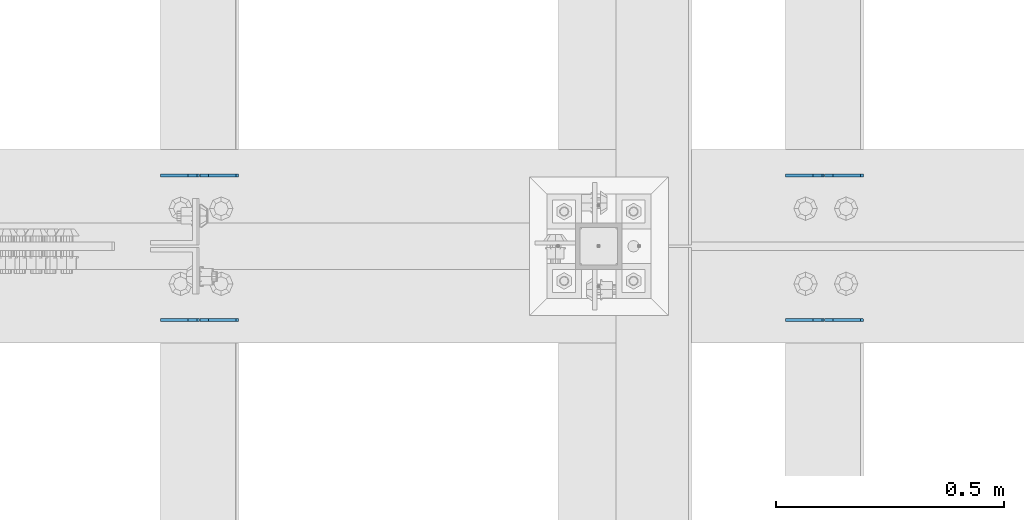
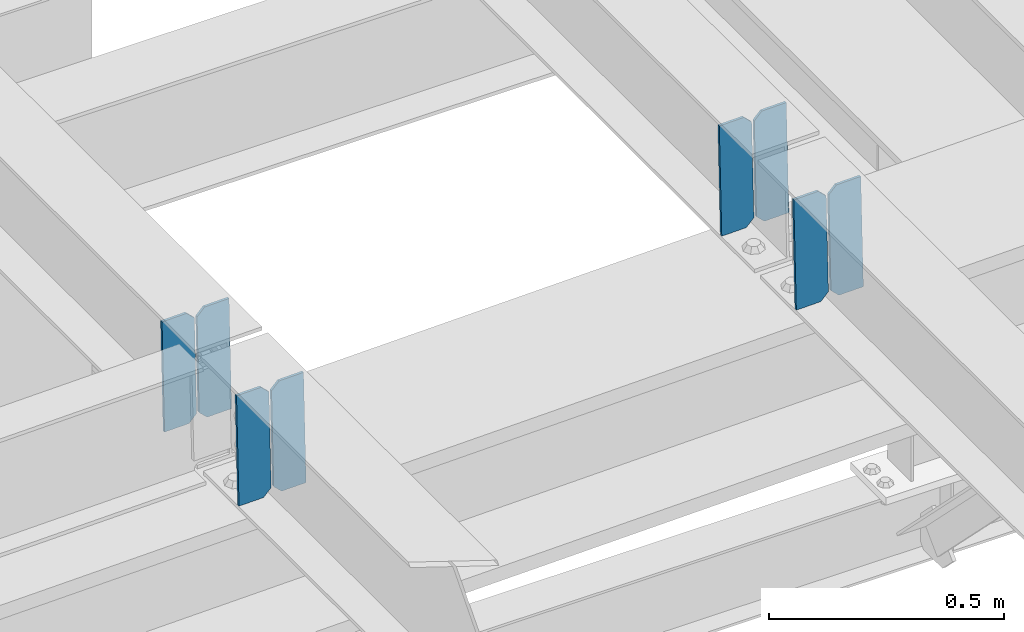
# One storey, part 3397 of 3843: 8 plates, 4 elements without a shape of their own.
"""IFC2X3 building model written with IfcOpenShell, lengths in millimetres."""

from ifc_helpers import new_model, si_unit, frame, origin_with_axes, place, context, subcontext, project, spatial, faceted_brep, material, type_object, element, aggregate, save


model = new_model("IFC2X3")

# Units and contexts
model_context = context("Model", 3, precision=1e-05, world=origin_with_axes())
body_context = subcontext(model_context, "Body", "Model", "MODEL_VIEW")
ifc_project = project(units=[si_unit("LENGTHUNIT", "METRE", prefix="MILLI"), si_unit("AREAUNIT", "SQUARE_METRE"), si_unit("VOLUMEUNIT", "CUBIC_METRE"), si_unit("MASSUNIT", "GRAM", prefix="KILO"), si_unit("TIMEUNIT", "SECOND"), si_unit("PLANEANGLEUNIT", "RADIAN"), si_unit("SOLIDANGLEUNIT", "STERADIAN"), si_unit("THERMODYNAMICTEMPERATUREUNIT", "DEGREE_CELSIUS"), si_unit("LUMINOUSINTENSITYUNIT", "LUMEN")], contexts=[model_context])

# Site, building, storey
site_placement = place(None, origin_with_axes())
site = spatial("IfcSite", under=ifc_project, at=site_placement, CompositionType="ELEMENT")
building_placement = place(site_placement, origin_with_axes())
building = spatial("IfcBuilding", under=site, at=building_placement, Name="Undefined", CompositionType="ELEMENT")
storey_placement = place(building_placement, origin_with_axes())
storey = spatial("IfcBuildingStorey", under=building, at=storey_placement, Name="Undefined", CompositionType="ELEMENT", Elevation=0.0)

# Assembly, plates
assembly_1_placement = place(storey_placement, origin_with_axes())
assembly_1 = element("IfcElementAssembly", 1, at=assembly_1_placement, inside=storey, Name="BEAM", AssemblyPlace="NOTDEFINED", PredefinedType="RIGID_FRAME")
ifc_material = material(Name="STEEL/A572-50")
plate_type = type_object("IfcPlateType", PredefinedType="NOTDEFINED")
plate_1_placement = place(assembly_1_placement, frame((39401.4964783447, 84140.6303417167, 45490.5687966606), z_axis=(-0.0211520982443035, 0.000149702000009711, 0.999776258134376), x_axis=(-0.999776269342228, -3.16699999781408e-06, -0.0211520980072162)))
plate_1 = element("IfcPlate", 2, at=plate_1_placement, type_object=plate_type, material=ifc_material, Name="PLATE", context=body_context, shape_type="Brep", body=[
    faceted_brep([(0.0, -3.17499999999927, 0.0), (6.83940015733242e-10, -3.17499999996653, 288.924999998613), (6.54836185276508e-10, 3.17500000001746, 288.924999998591), (0.0, 3.17499999999927, 0.0), (60.3250007643655, -3.17500000017753, 288.924999998606), (60.3250007643219, 3.17499999979918, 288.924999998584), (79.3750000013097, -3.17500000025029, 269.875000761494), (79.375000001266, 3.17499999972642, 269.875000761487), (79.375000000713, -3.17500000026484, 19.0499992370605), (79.3750000006985, 3.17499999971187, 19.0499992370533), (60.325000763667, -3.17500000020664, -1.45519152283669e-11), (60.3250007636234, 3.17499999977736, -3.63797880709171e-11)], [[[0, 1, 2, 3]], [[1, 4, 5, 2]], [[4, 6, 7, 5]], [[6, 8, 9, 7]], [[8, 10, 11, 9]], [[10, 0, 3, 11]], [[5, 7, 9, 11, 3, 2]], [[10, 8, 6, 4, 1, 0]]]),
])
plate_2_placement = place(assembly_1_placement, frame((39315.7906576554, 84140.6300702067, 45488.75553308), z_axis=(-0.0211520982443035, 0.000149702000009711, 0.999776258134376), x_axis=(-0.999776269342228, -3.16699999781408e-06, -0.0211520980072162)))
plate_2 = element("IfcPlate", 3, at=plate_2_placement, type_object=plate_type, material=ifc_material, Name="PLATE", context=body_context, shape_type="Brep", body=[
    faceted_brep([(4.36557456851006e-11, -3.17499999998836, 19.0499992370969), (6.11180439591408e-10, -3.17499999996653, 269.875000761516), (5.96628524363041e-10, 3.17500000001746, 269.875000761502), (1.45519152283669e-11, 3.17499999998836, 19.0499992370824), (19.0499992376572, -3.17500000003201, 288.924999998606), (19.0499992376281, 3.1749999999447, 288.924999998584), (79.3750000013242, -3.17500000025029, 288.924999998591), (79.3750000013097, 3.1749999997337, 288.92499999857), (79.3750000006548, -3.17500000026484, -2.18278728425503e-11), (79.3750000006403, 3.17499999969732, -2.91038304567337e-11), (19.0499992370023, -3.17500000005384, 0.0), (19.0499992369587, 3.17499999992287, -1.45519152283669e-11)], [[[0, 1, 2, 3]], [[1, 4, 5, 2]], [[4, 6, 7, 5]], [[6, 8, 9, 7]], [[8, 10, 11, 9]], [[10, 0, 3, 11]], [[5, 7, 9, 11, 3, 2]], [[10, 8, 6, 4, 1, 0]]]),
])
aggregate(assembly_1, [plate_1, plate_2])

assembly_2_placement = place(storey_placement, origin_with_axes())
assembly_2 = element("IfcElementAssembly", 4, at=assembly_2_placement, inside=storey, Name="BEAM", AssemblyPlace="NOTDEFINED", PredefinedType="RIGID_FRAME")
plate_3_placement = place(assembly_2_placement, frame((39401.4964782663, 83822.7338308514, 45490.8324863675), z_axis=(-0.0211520981891954, 0.00148016899947834, 0.999775173647519), x_axis=(-0.999776269354785, -3.22879999736168e-05, -0.0211520730074938)))
plate_3 = element("IfcPlate", 5, at=plate_3_placement, type_object=plate_type, material=ifc_material, Name="PLATE", context=body_context, shape_type="Brep", body=[
    faceted_brep([(0.0, -3.17499999999927, 0.0), (6.83940015733242e-10, -3.17499999996653, 288.924999998613), (6.54836185276508e-10, 3.17500000001746, 288.924999998591), (0.0, 3.17499999999927, 0.0), (60.3250007643655, -3.17500000017753, 288.924999998606), (60.3250007643219, 3.17499999979918, 288.924999998584), (79.3750000013097, -3.17500000025029, 269.875000761494), (79.375000001266, 3.17499999972642, 269.875000761487), (79.375000000713, -3.17500000026484, 19.0499992370605), (79.3750000006985, 3.17499999971187, 19.0499992370533), (60.325000763667, -3.17500000020664, -1.45519152283669e-11), (60.3250007636234, 3.17499999977736, -3.63797880709171e-11)], [[[0, 1, 2, 3]], [[1, 4, 5, 2]], [[4, 6, 7, 5]], [[6, 8, 9, 7]], [[8, 10, 11, 9]], [[10, 0, 3, 11]], [[5, 7, 9, 11, 3, 2]], [[10, 8, 6, 4, 1, 0]]]),
])
plate_4_placement = place(assembly_2_placement, frame((39315.7906575769, 83822.731146315, 45489.0192247541), z_axis=(-0.0211520981891954, 0.00148016899947834, 0.999775173647519), x_axis=(-0.999776269354785, -3.22879999736168e-05, -0.0211520730074938)))
plate_4 = element("IfcPlate", 6, at=plate_4_placement, type_object=plate_type, material=ifc_material, Name="PLATE", context=body_context, shape_type="Brep", body=[
    faceted_brep([(4.36557456851006e-11, -3.17499999998836, 19.0499992370969), (6.11180439591408e-10, -3.17499999996653, 269.875000761516), (5.96628524363041e-10, 3.17500000001746, 269.875000761502), (1.45519152283669e-11, 3.17499999998836, 19.0499992370824), (19.0499992376572, -3.17500000003201, 288.924999998606), (19.0499992376281, 3.1749999999447, 288.924999998584), (79.3750000013242, -3.17500000025029, 288.924999998591), (79.3750000013097, 3.1749999997337, 288.92499999857), (79.3750000006548, -3.17500000026484, -2.18278728425503e-11), (79.3750000006403, 3.17499999969732, -2.91038304567337e-11), (19.0499992370023, -3.17500000005384, 0.0), (19.0499992369587, 3.17499999992287, -1.45519152283669e-11)], [[[0, 1, 2, 3]], [[1, 4, 5, 2]], [[4, 6, 7, 5]], [[6, 8, 9, 7]], [[8, 10, 11, 9]], [[10, 0, 3, 11]], [[5, 7, 9, 11, 3, 2]], [[10, 8, 6, 4, 1, 0]]]),
])
aggregate(assembly_2, [plate_3, plate_4])

assembly_3_placement = place(storey_placement, origin_with_axes())
assembly_3 = element("IfcElementAssembly", 7, at=assembly_3_placement, inside=storey, Name="BEAM", AssemblyPlace="NOTDEFINED", PredefinedType="RIGID_FRAME")
plate_5_placement = place(assembly_3_placement, frame((38029.8964783739, 84140.6526717406, 45460.8999585704), z_axis=(-0.0211520980636923, 7.39979999707428e-05, 0.999776266607585), x_axis=(-0.999776269345987, -1.58399999781977e-06, -0.021152098007311)))
plate_5 = element("IfcPlate", 8, at=plate_5_placement, type_object=plate_type, material=ifc_material, Name="PLATE", context=body_context, shape_type="Brep", body=[
    faceted_brep([(0.0, -3.17499999999927, 0.0), (6.83940015733242e-10, -3.17499999996653, 288.924999998613), (6.54836185276508e-10, 3.17500000001746, 288.924999998591), (0.0, 3.17499999999927, 0.0), (60.3250007643655, -3.17500000017753, 288.924999998606), (60.3250007643219, 3.17499999979918, 288.924999998584), (79.3750000013097, -3.17500000025029, 269.875000761494), (79.375000001266, 3.17499999972642, 269.875000761487), (79.375000000713, -3.17500000026484, 19.0499992370605), (79.3750000006985, 3.17499999971187, 19.0499992370533), (60.325000763667, -3.17500000020664, -1.45519152283669e-11), (60.3250007636234, 3.17499999977736, -3.63797880709171e-11)], [[[0, 1, 2, 3]], [[1, 4, 5, 2]], [[4, 6, 7, 5]], [[6, 8, 9, 7]], [[8, 10, 11, 9]], [[10, 0, 3, 11]], [[5, 7, 9, 11, 3, 2]], [[10, 8, 6, 4, 1, 0]]]),
])
plate_6_placement = place(assembly_3_placement, frame((37944.1906576846, 84140.6525359852, 45459.0866949754), z_axis=(-0.0211520980636923, 7.39979999707428e-05, 0.999776266607585), x_axis=(-0.999776269345987, -1.58399999781977e-06, -0.021152098007311)))
plate_6 = element("IfcPlate", 9, at=plate_6_placement, type_object=plate_type, material=ifc_material, Name="PLATE", context=body_context, shape_type="Brep", body=[
    faceted_brep([(4.36557456851006e-11, -3.17499999998836, 19.0499992370969), (6.11180439591408e-10, -3.17499999996653, 269.875000761516), (5.96628524363041e-10, 3.17500000001746, 269.875000761502), (1.45519152283669e-11, 3.17499999998836, 19.0499992370824), (19.0499992376572, -3.17500000003201, 288.924999998606), (19.0499992376281, 3.1749999999447, 288.924999998584), (79.3750000013242, -3.17500000025029, 288.924999998591), (79.3750000013097, 3.1749999997337, 288.92499999857), (79.3750000006548, -3.17500000026484, -2.18278728425503e-11), (79.3750000006403, 3.17499999969732, -2.91038304567337e-11), (19.0499992370023, -3.17500000005384, 0.0), (19.0499992369587, 3.17499999992287, -1.45519152283669e-11)], [[[0, 1, 2, 3]], [[1, 4, 5, 2]], [[4, 6, 7, 5]], [[6, 8, 9, 7]], [[8, 10, 11, 9]], [[10, 0, 3, 11]], [[5, 7, 9, 11, 3, 2]], [[10, 8, 6, 4, 1, 0]]]),
])
aggregate(assembly_3, [plate_5, plate_6])

assembly_4_placement = place(storey_placement, origin_with_axes())
assembly_4 = element("IfcElementAssembly", 10, at=assembly_4_placement, inside=storey, Name="BEAM", AssemblyPlace="NOTDEFINED", PredefinedType="RIGID_FRAME")
plate_7_placement = place(assembly_4_placement, frame((38029.8964783223, 83822.9486350603, 45461.0347362922), z_axis=(-0.0211520981056674, 0.000759183000074701, 0.999775981101217), x_axis=(-0.999776269340625, -1.63420000828851e-05, -0.0211520920071849)))
plate_7 = element("IfcPlate", 11, at=plate_7_placement, type_object=plate_type, material=ifc_material, Name="PLATE", context=body_context, shape_type="Brep", body=[
    faceted_brep([(0.0, -3.17499999999927, 0.0), (6.83940015733242e-10, -3.17499999996653, 288.924999998613), (6.54836185276508e-10, 3.17500000001746, 288.924999998591), (0.0, 3.17499999999927, 0.0), (60.3250007643655, -3.17500000017753, 288.924999998606), (60.3250007643219, 3.17499999979918, 288.924999998584), (79.3750000013097, -3.17500000025029, 269.875000761494), (79.375000001266, 3.17499999972642, 269.875000761487), (79.375000000713, -3.17500000026484, 19.0499992370605), (79.3750000006985, 3.17499999971187, 19.0499992370533), (60.325000763667, -3.17500000020664, -1.45519152283669e-11), (60.3250007636234, 3.17499999977736, -3.63797880709171e-11)], [[[0, 1, 2, 3]], [[1, 4, 5, 2]], [[4, 6, 7, 5]], [[6, 8, 9, 7]], [[8, 10, 11, 9]], [[10, 0, 3, 11]], [[5, 7, 9, 11, 3, 2]], [[10, 8, 6, 4, 1, 0]]]),
])
plate_8_placement = place(assembly_4_placement, frame((37944.190657633, 83822.947258153, 45459.2214732136), z_axis=(-0.0211520981056674, 0.000759183000074701, 0.999775981101217), x_axis=(-0.999776269340625, -1.63420000828851e-05, -0.0211520920071849)))
plate_8 = element("IfcPlate", 12, at=plate_8_placement, type_object=plate_type, material=ifc_material, Name="PLATE", context=body_context, shape_type="Brep", body=[
    faceted_brep([(4.36557456851006e-11, -3.17499999998836, 19.0499992370969), (6.11180439591408e-10, -3.17499999996653, 269.875000761516), (5.96628524363041e-10, 3.17500000001746, 269.875000761502), (1.45519152283669e-11, 3.17499999998836, 19.0499992370824), (19.0499992376572, -3.17500000003201, 288.924999998606), (19.0499992376281, 3.1749999999447, 288.924999998584), (79.3750000013242, -3.17500000025029, 288.924999998591), (79.3750000013097, 3.1749999997337, 288.92499999857), (79.3750000006548, -3.17500000026484, -2.18278728425503e-11), (79.3750000006403, 3.17499999969732, -2.91038304567337e-11), (19.0499992370023, -3.17500000005384, 0.0), (19.0499992369587, 3.17499999992287, -1.45519152283669e-11)], [[[0, 1, 2, 3]], [[1, 4, 5, 2]], [[4, 6, 7, 5]], [[6, 8, 9, 7]], [[8, 10, 11, 9]], [[10, 0, 3, 11]], [[5, 7, 9, 11, 3, 2]], [[10, 8, 6, 4, 1, 0]]]),
])
aggregate(assembly_4, [plate_7, plate_8])

save(model, "model.ifc")
